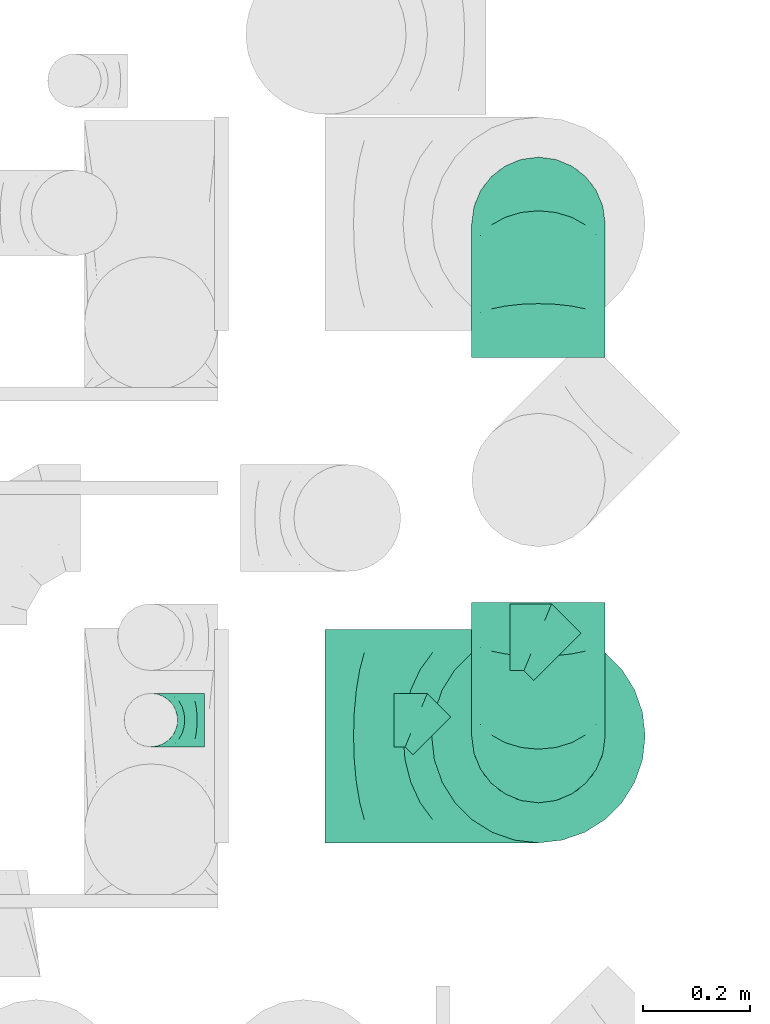
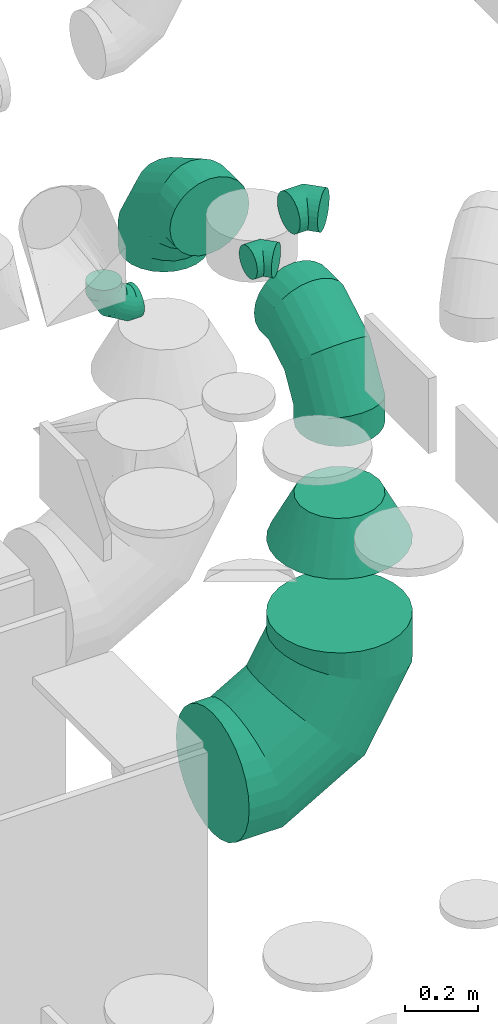
# One storey, part 26 of 59: 7 flow fittings.
"""IFC2X3 building model written with IfcOpenShell, lengths in millimetres."""

from ifc_helpers import new_model, entity, si_unit, converted_unit, derived_unit, direction, frame, origin, place, context, subcontext, project, spatial, faceted_brep, source, transform, mapped, material, type_object, type_shapes, element, save


model = new_model("IFC2X3")

# Units and contexts
model_context = context("Model", 3, precision=0.01, world=origin(), true_north=direction((6.12303176911189e-17, 1.0)))
body_context = subcontext(model_context, "Body", "Model", "MODEL_VIEW")
ifc_project = project(units=[si_unit("LENGTHUNIT", "METRE", prefix="MILLI"), si_unit("AREAUNIT", "SQUARE_METRE"), si_unit("VOLUMEUNIT", "CUBIC_METRE"), converted_unit("PLANEANGLEUNIT", "DEGREE", entity("IfcRatioMeasure", 0.0174532925199433), si_unit("PLANEANGLEUNIT", "RADIAN"), dimensions=[0, 0, 0, 0, 0, 0, 0]), si_unit("MASSUNIT", "GRAM", prefix="KILO"), derived_unit("MASSDENSITYUNIT", [(si_unit("MASSUNIT", "GRAM", prefix="KILO"), 1), (si_unit("LENGTHUNIT", "METRE"), -3)]), derived_unit("MOMENTOFINERTIAUNIT", [(si_unit("LENGTHUNIT", "METRE"), 4)]), si_unit("TIMEUNIT", "SECOND"), si_unit("FREQUENCYUNIT", "HERTZ"), si_unit("THERMODYNAMICTEMPERATUREUNIT", "DEGREE_CELSIUS"), derived_unit("THERMALTRANSMITTANCEUNIT", [(si_unit("MASSUNIT", "GRAM", prefix="KILO"), 1), (si_unit("THERMODYNAMICTEMPERATUREUNIT", "KELVIN"), -1), (si_unit("TIMEUNIT", "SECOND"), -3)]), derived_unit("VOLUMETRICFLOWRATEUNIT", [(si_unit("LENGTHUNIT", "METRE"), 3), (si_unit("TIMEUNIT", "SECOND"), -1)]), derived_unit("MASSFLOWRATEUNIT", [(si_unit("MASSUNIT", "GRAM", prefix="KILO"), 1), (si_unit("TIMEUNIT", "SECOND"), -1)]), derived_unit("ROTATIONALFREQUENCYUNIT", [(si_unit("TIMEUNIT", "SECOND"), -1)]), si_unit("ELECTRICCURRENTUNIT", "AMPERE"), si_unit("ELECTRICVOLTAGEUNIT", "VOLT"), si_unit("POWERUNIT", "WATT"), si_unit("FORCEUNIT", "NEWTON", prefix="KILO"), si_unit("ILLUMINANCEUNIT", "LUX"), si_unit("LUMINOUSFLUXUNIT", "LUMEN"), si_unit("LUMINOUSINTENSITYUNIT", "CANDELA"), derived_unit("USERDEFINED", [(si_unit("MASSUNIT", "GRAM", prefix="KILO"), -1), (si_unit("LENGTHUNIT", "METRE"), -2), (si_unit("TIMEUNIT", "SECOND"), 3), (si_unit("LUMINOUSFLUXUNIT", "LUMEN"), 1)]), derived_unit("LINEARVELOCITYUNIT", [(si_unit("LENGTHUNIT", "METRE"), 1), (si_unit("TIMEUNIT", "SECOND"), -1)]), si_unit("PRESSUREUNIT", "PASCAL"), derived_unit("USERDEFINED", [(si_unit("LENGTHUNIT", "METRE"), -2), (si_unit("MASSUNIT", "GRAM", prefix="KILO"), 1), (si_unit("TIMEUNIT", "SECOND"), -2)]), derived_unit("LINEARFORCEUNIT", [(si_unit("MASSUNIT", "GRAM", prefix="KILO"), 1), (si_unit("LENGTHUNIT", "METRE"), 1), (si_unit("TIMEUNIT", "SECOND"), -2), (si_unit("LENGTHUNIT", "METRE"), -1)]), derived_unit("PLANARFORCEUNIT", [(si_unit("MASSUNIT", "GRAM", prefix="KILO"), 1), (si_unit("LENGTHUNIT", "METRE"), 1), (si_unit("TIMEUNIT", "SECOND"), -2), (si_unit("LENGTHUNIT", "METRE"), -2)])], contexts=[model_context])

# Site, building, storey
site_placement = place(None, origin())
site = spatial("IfcSite", under=ifc_project, at=site_placement, CompositionType="ELEMENT")
building_placement = place(site_placement, origin())
building = spatial("IfcBuilding", under=site, at=building_placement, CompositionType="ELEMENT")
storey_placement = place(building_placement, frame((0.0, 0.0, 28200.0)))
storey = spatial("IfcBuildingStorey", under=building, at=storey_placement, CompositionType="ELEMENT", Elevation=28200.0)

# Flow fittings
ifc_material = material()
duct_fitting_type_1 = type_object("IfcDuctFittingType", PredefinedType="NOTDEFINED", material=ifc_material)
shared_shape_1 = source(origin(), body_context, "Body", "Brep", [
    faceted_brep([(-100.0, 0.0, -50.0), (-100.0, -12.94, -48.3), (-100.0, -25.0, -43.3), (-100.0, -35.36, -35.36), (-100.0, -43.3, -25.0), (-100.0, -48.3, -12.94), (-100.0, -50.0, 0.0), (-100.0, -48.3, 12.94), (-100.0, -43.3, 25.0), (-100.0, -35.36, 35.36), (-100.0, -25.0, 43.3), (-100.0, -12.94, 48.3), (-100.0, 0.0, 50.0), (-100.0, 12.94, 48.3), (-100.0, 25.0, 43.3), (-100.0, 35.36, 35.36), (-100.0, 43.3, 25.0), (-100.0, 48.3, 12.94), (-100.0, 50.0, 0.0), (-100.0, 48.3, -12.94), (-100.0, 43.3, -25.0), (-100.0, 35.36, -35.36), (-100.0, 25.0, -43.3), (-100.0, 12.94, -48.3), (-76.67, 12.94, 48.3), (-79.9, 25.0, 43.3), (-73.21, 0.0, 50.0), (-82.68, 35.36, 35.36), (-86.15, 48.3, 12.94), (-86.6, 50.0, 0.0), (-84.81, 43.3, 25.0), (-84.81, 43.3, -25.0), (-82.68, 35.36, -35.36), (-86.15, 48.3, -12.94), (-76.67, 12.94, -48.3), (-73.21, 0.0, -50.0), (-79.9, 25.0, -43.3), (-69.74, -12.94, -48.3), (-66.51, -25.0, -43.3), (-63.73, -35.36, -35.36), (-61.6, -43.3, -25.0), (-60.26, -48.3, -12.94), (-59.81, -50.0, 0.0), (-60.26, -48.3, 12.94), (-61.6, -43.3, 25.0), (-63.73, -35.36, 35.36), (-66.51, -25.0, 43.3), (-69.74, -12.94, 48.3), (-36.27, 36.27, 48.3), (-45.1, 45.1, 43.3), (-26.79, 26.79, 50.0), (-52.68, 52.68, 35.36), (-58.49, 58.49, 25.0), (-62.15, 62.15, 12.94), (-63.4, 63.4, 0.0), (-62.15, 62.15, -12.94), (-58.49, 58.49, -25.0), (-52.68, 52.68, -35.36), (-36.27, 36.27, -48.3), (-26.79, 26.79, -50.0), (-45.1, 45.1, -43.3), (-17.32, 17.32, -48.3), (-8.49, 8.49, -43.3), (-0.91, 0.91, -35.36), (4.9, -4.9, -25.0), (8.56, -8.56, -12.94), (9.81, -9.81, 0.0), (8.56, -8.56, 12.94), (4.9, -4.9, 25.0), (-0.91, 0.91, 35.36), (-8.49, 8.49, 43.3), (-17.32, 17.32, 48.3), (-12.94, 76.67, 48.3), (-25.0, 79.9, 43.3), (0.0, 73.21, 50.0), (-35.36, 82.68, 35.36), (-43.3, 84.81, 25.0), (-48.3, 86.15, 12.94), (-50.0, 86.6, 0.0), (-48.3, 86.15, -12.94), (-43.3, 84.81, -25.0), (-35.36, 82.68, -35.36), (-12.94, 76.67, -48.3), (0.0, 73.21, -50.0), (-25.0, 79.9, -43.3), (12.94, 69.74, -48.3), (25.0, 66.51, -43.3), (35.36, 63.73, -35.36), (43.3, 61.6, -25.0), (48.3, 60.26, -12.94), (50.0, 59.81, 0.0), (48.3, 60.26, 12.94), (43.3, 61.6, 25.0), (35.36, 63.73, 35.36), (25.0, 66.51, 43.3), (12.94, 69.74, 48.3), (-12.94, 100.0, -48.3), (-25.0, 100.0, -43.3), (-35.36, 100.0, -35.36), (-43.3, 100.0, -25.0), (-48.3, 100.0, -12.94), (-50.0, 100.0, 0.0), (-48.3, 100.0, 12.94), (-43.3, 100.0, 25.0), (-35.36, 100.0, 35.36), (-25.0, 100.0, 43.3), (-12.94, 100.0, 48.3), (0.0, 100.0, 50.0), (12.94, 100.0, 48.3), (25.0, 100.0, 43.3), (35.36, 100.0, 35.36), (43.3, 100.0, 25.0), (48.3, 100.0, 12.94), (50.0, 100.0, 0.0), (48.3, 100.0, -12.94), (43.3, 100.0, -25.0), (35.36, 100.0, -35.36), (25.0, 100.0, -43.3), (12.94, 100.0, -48.3), (0.0, 100.0, -50.0)], [[[0, 1, 2, 3, 4, 5, 6, 7, 8, 9, 10, 11, 12, 13, 14, 15, 16, 17, 18, 19, 20, 21, 22, 23]], [[24, 25, 14, 13]], [[26, 24, 13, 12]], [[14, 25, 27, 15]], [[28, 29, 18, 17]], [[30, 28, 17, 16]], [[15, 27, 30, 16]], [[20, 31, 32, 21]], [[33, 31, 20, 19]], [[18, 29, 33, 19]], [[34, 35, 0, 23]], [[36, 34, 23, 22]], [[32, 36, 22, 21]], [[2, 1, 37, 38]], [[3, 2, 38, 39]], [[0, 35, 37, 1]], [[5, 4, 40, 41]], [[6, 5, 41, 42]], [[3, 39, 40, 4]], [[6, 42, 43, 7]], [[7, 43, 44, 8]], [[8, 44, 45, 9]], [[10, 46, 47, 11]], [[11, 47, 26, 12]], [[10, 9, 45, 46]], [[48, 49, 25, 24]], [[50, 48, 24, 26]], [[27, 25, 49, 51]], [[52, 53, 28, 30]], [[51, 52, 30, 27]], [[29, 28, 53, 54]], [[55, 56, 31, 33]], [[54, 55, 33, 29]], [[57, 32, 31, 56]], [[58, 59, 35, 34]], [[60, 58, 34, 36]], [[57, 60, 36, 32]], [[37, 35, 59, 61]], [[38, 37, 61, 62]], [[39, 38, 62, 63]], [[41, 40, 64, 65]], [[42, 41, 65, 66]], [[63, 64, 40, 39]], [[43, 42, 66, 67]], [[44, 43, 67, 68]], [[68, 69, 45, 44]], [[46, 45, 69, 70]], [[47, 46, 70, 71]], [[26, 47, 71, 50]], [[72, 73, 49, 48]], [[74, 72, 48, 50]], [[51, 49, 73, 75]], [[76, 77, 53, 52]], [[75, 76, 52, 51]], [[54, 53, 77, 78]], [[79, 80, 56, 55]], [[78, 79, 55, 54]], [[81, 57, 56, 80]], [[82, 83, 59, 58]], [[84, 82, 58, 60]], [[81, 84, 60, 57]], [[61, 59, 83, 85]], [[62, 61, 85, 86]], [[63, 62, 86, 87]], [[65, 64, 88, 89]], [[66, 65, 89, 90]], [[87, 88, 64, 63]], [[67, 66, 90, 91]], [[68, 67, 91, 92]], [[92, 93, 69, 68]], [[70, 69, 93, 94]], [[71, 70, 94, 95]], [[50, 71, 95, 74]], [[96, 97, 98, 99, 100, 101, 102, 103, 104, 105, 106, 107, 108, 109, 110, 111, 112, 113, 114, 115, 116, 117, 118, 119]], [[72, 74, 107, 106]], [[73, 72, 106, 105]], [[75, 73, 105, 104]], [[77, 76, 103, 102]], [[78, 77, 102, 101]], [[75, 104, 103, 76]], [[78, 101, 100, 79]], [[79, 100, 99, 80]], [[80, 99, 98, 81]], [[96, 119, 83, 82]], [[97, 96, 82, 84]], [[84, 81, 98, 97]], [[83, 119, 118, 85]], [[85, 118, 117, 86]], [[86, 117, 116, 87]], [[88, 115, 114, 89]], [[89, 114, 113, 90]], [[87, 116, 115, 88]], [[91, 90, 113, 112]], [[92, 91, 112, 111]], [[93, 92, 111, 110]], [[95, 94, 109, 108]], [[74, 95, 108, 107]], [[110, 109, 94, 93]]]),
])
type_shapes(duct_fitting_type_1, [shared_shape_1])
flow_fitting_1_placement = place(storey_placement, frame((55594.42, 10907.71, 2305.0), z_axis=(0.0, -1.0, 0.0), x_axis=(0.0, 0.0, -1.0)))
element("IfcFlowFitting", 1, at=flow_fitting_1_placement, inside=storey, type_object=duct_fitting_type_1, material=ifc_material, context=body_context, shape_type="MappedRepresentation", body=[
    mapped(shared_shape_1, transform((0.0, 0.0, 0.0), scale=1.0)),
])
duct_fitting_type_2 = type_object("IfcDuctFittingType", PredefinedType="NOTDEFINED", material=ifc_material)
shared_shape_2 = source(origin(), body_context, "Body", "Brep", [
    faceted_brep([(-250.0, 0.0, -125.0), (-250.0, -32.35, -120.74), (-250.0, -62.5, -108.25), (-250.0, -88.39, -88.39), (-250.0, -108.25, -62.5), (-250.0, -120.74, -32.35), (-250.0, -125.0, 0.0), (-250.0, -120.74, 32.35), (-250.0, -108.25, 62.5), (-250.0, -88.39, 88.39), (-250.0, -62.5, 108.25), (-250.0, -32.35, 120.74), (-250.0, 0.0, 125.0), (-250.0, 32.35, 120.74), (-250.0, 62.5, 108.25), (-250.0, 88.39, 88.39), (-250.0, 108.25, 62.5), (-250.0, 120.74, 32.35), (-250.0, 125.0, 0.0), (-250.0, 120.74, -32.35), (-250.0, 108.25, -62.5), (-250.0, 88.39, -88.39), (-250.0, 62.5, -108.25), (-250.0, 32.35, -120.74), (-191.68, 32.35, 120.74), (-199.76, 62.5, 108.25), (-183.01, 0.0, 125.0), (-206.7, 88.39, 88.39), (-215.37, 120.74, 32.35), (-216.51, 125.0, 0.0), (-212.02, 108.25, 62.5), (-212.02, 108.25, -62.5), (-206.7, 88.39, -88.39), (-215.37, 120.74, -32.35), (-191.68, 32.35, -120.74), (-183.01, 0.0, -125.0), (-199.76, 62.5, -108.25), (-174.34, -32.35, -120.74), (-166.27, -62.5, -108.25), (-159.33, -88.39, -88.39), (-154.01, -108.25, -62.5), (-150.66, -120.74, -32.35), (-149.52, -125.0, 0.0), (-150.66, -120.74, 32.35), (-154.01, -108.25, 62.5), (-159.33, -88.39, 88.39), (-166.27, -62.5, 108.25), (-174.34, -32.35, 120.74), (-90.67, 90.67, 120.74), (-112.74, 112.74, 108.25), (-66.99, 66.99, 125.0), (-131.69, 131.69, 88.39), (-146.23, 146.23, 62.5), (-155.38, 155.38, 32.35), (-158.49, 158.49, 0.0), (-155.38, 155.38, -32.35), (-146.23, 146.23, -62.5), (-131.69, 131.69, -88.39), (-90.67, 90.67, -120.74), (-66.99, 66.99, -125.0), (-112.74, 112.74, -108.25), (-43.3, 43.3, -120.74), (-21.23, 21.23, -108.25), (-2.28, 2.28, -88.39), (12.26, -12.26, -62.5), (21.4, -21.4, -32.35), (24.52, -24.52, 0.0), (21.4, -21.4, 32.35), (12.26, -12.26, 62.5), (-2.28, 2.28, 88.39), (-21.23, 21.23, 108.25), (-43.3, 43.3, 120.74), (-32.35, 191.68, 120.74), (-62.5, 199.76, 108.25), (0.0, 183.01, 125.0), (-88.39, 206.7, 88.39), (-108.25, 212.02, 62.5), (-120.74, 215.37, 32.35), (-125.0, 216.51, 0.0), (-120.74, 215.37, -32.35), (-108.25, 212.02, -62.5), (-88.39, 206.7, -88.39), (-32.35, 191.68, -120.74), (0.0, 183.01, -125.0), (-62.5, 199.76, -108.25), (32.35, 174.34, -120.74), (62.5, 166.27, -108.25), (88.39, 159.33, -88.39), (108.25, 154.01, -62.5), (120.74, 150.66, -32.35), (125.0, 149.52, 0.0), (120.74, 150.66, 32.35), (108.25, 154.01, 62.5), (88.39, 159.33, 88.39), (62.5, 166.27, 108.25), (32.35, 174.34, 120.74), (-32.35, 250.0, -120.74), (-62.5, 250.0, -108.25), (-88.39, 250.0, -88.39), (-108.25, 250.0, -62.5), (-120.74, 250.0, -32.35), (-125.0, 250.0, 0.0), (-120.74, 250.0, 32.35), (-108.25, 250.0, 62.5), (-88.39, 250.0, 88.39), (-62.5, 250.0, 108.25), (-32.35, 250.0, 120.74), (0.0, 250.0, 125.0), (32.35, 250.0, 120.74), (62.5, 250.0, 108.25), (88.39, 250.0, 88.39), (108.25, 250.0, 62.5), (120.74, 250.0, 32.35), (125.0, 250.0, 0.0), (120.74, 250.0, -32.35), (108.25, 250.0, -62.5), (88.39, 250.0, -88.39), (62.5, 250.0, -108.25), (32.35, 250.0, -120.74), (0.0, 250.0, -125.0)], [[[0, 1, 2, 3, 4, 5, 6, 7, 8, 9, 10, 11, 12, 13, 14, 15, 16, 17, 18, 19, 20, 21, 22, 23]], [[24, 25, 14, 13]], [[26, 24, 13, 12]], [[14, 25, 27, 15]], [[28, 29, 18, 17]], [[30, 28, 17, 16]], [[15, 27, 30, 16]], [[20, 31, 32, 21]], [[33, 31, 20, 19]], [[18, 29, 33, 19]], [[34, 35, 0, 23]], [[36, 34, 23, 22]], [[21, 32, 36, 22]], [[1, 0, 35, 37]], [[2, 1, 37, 38]], [[38, 39, 3, 2]], [[5, 4, 40, 41]], [[6, 5, 41, 42]], [[39, 40, 4, 3]], [[6, 42, 43, 7]], [[7, 43, 44, 8]], [[8, 44, 45, 9]], [[9, 45, 46, 10]], [[10, 46, 47, 11]], [[26, 12, 11, 47]], [[48, 49, 25, 24]], [[50, 48, 24, 26]], [[27, 25, 49, 51]], [[52, 53, 28, 30]], [[51, 52, 30, 27]], [[29, 28, 53, 54]], [[55, 56, 31, 33]], [[54, 55, 33, 29]], [[32, 31, 56, 57]], [[58, 59, 35, 34]], [[60, 58, 34, 36]], [[57, 60, 36, 32]], [[37, 35, 59, 61]], [[38, 37, 61, 62]], [[39, 38, 62, 63]], [[41, 40, 64, 65]], [[42, 41, 65, 66]], [[63, 64, 40, 39]], [[43, 42, 66, 67]], [[44, 43, 67, 68]], [[68, 69, 45, 44]], [[46, 45, 69, 70]], [[47, 46, 70, 71]], [[26, 47, 71, 50]], [[72, 73, 49, 48]], [[74, 72, 48, 50]], [[51, 49, 73, 75]], [[76, 77, 53, 52]], [[75, 76, 52, 51]], [[54, 53, 77, 78]], [[79, 80, 56, 55]], [[78, 79, 55, 54]], [[57, 56, 80, 81]], [[82, 83, 59, 58]], [[84, 82, 58, 60]], [[81, 84, 60, 57]], [[61, 59, 83, 85]], [[62, 61, 85, 86]], [[63, 62, 86, 87]], [[65, 64, 88, 89]], [[66, 65, 89, 90]], [[87, 88, 64, 63]], [[67, 66, 90, 91]], [[68, 67, 91, 92]], [[92, 93, 69, 68]], [[70, 69, 93, 94]], [[71, 70, 94, 95]], [[50, 71, 95, 74]], [[96, 97, 98, 99, 100, 101, 102, 103, 104, 105, 106, 107, 108, 109, 110, 111, 112, 113, 114, 115, 116, 117, 118, 119]], [[72, 74, 107, 106]], [[73, 72, 106, 105]], [[75, 73, 105, 104]], [[77, 76, 103, 102]], [[78, 77, 102, 101]], [[75, 104, 103, 76]], [[78, 101, 100, 79]], [[79, 100, 99, 80]], [[80, 99, 98, 81]], [[84, 97, 96, 82]], [[82, 96, 119, 83]], [[84, 81, 98, 97]], [[83, 119, 118, 85]], [[85, 118, 117, 86]], [[116, 87, 86, 117]], [[88, 115, 114, 89]], [[89, 114, 113, 90]], [[115, 88, 87, 116]], [[91, 90, 113, 112]], [[92, 91, 112, 111]], [[111, 110, 93, 92]], [[95, 94, 109, 108]], [[74, 95, 108, 107]], [[110, 109, 94, 93]]]),
])
type_shapes(duct_fitting_type_2, [shared_shape_2])
for number, where, z_axis, x_axis in (
    (2, (56320.5, 10877.69, 1950.82), (1.0, 0.0, 0.0), (0.0, -1.0, 0.0)),
    (3, (56320.5, 11837.37, 1950.82), (-1.0, 0.0, 0.0), (0.0, 1.0, 0.0)),
):
    element("IfcFlowFitting", number, at=place(storey_placement, frame(where, z_axis=z_axis, x_axis=x_axis)), inside=storey, type_object=duct_fitting_type_2, material=ifc_material, context=body_context, shape_type="MappedRepresentation", body=[
        mapped(shared_shape_2, transform((0.0, 0.0, 0.0), scale=1.0)),
    ])
duct_fitting_type_3 = type_object("IfcDuctFittingType", PredefinedType="NOTDEFINED", material=ifc_material)
shared_shape_3 = source(origin(), body_context, "Body", "Brep", [
    faceted_brep([(-51.78, 0.0, -62.5), (-51.78, -16.18, -60.37), (-51.78, -31.25, -54.13), (-51.78, -44.19, -44.19), (-51.78, -54.13, -31.25), (-51.78, -60.37, -16.18), (-51.78, -62.5, 0.0), (-51.78, -60.37, 16.18), (-51.78, -54.13, 31.25), (-51.78, -44.19, 44.19), (-51.78, -31.25, 54.13), (-51.78, -16.18, 60.37), (-51.78, 0.0, 62.5), (-51.78, 16.18, 60.37), (-51.78, 31.25, 54.13), (-51.78, 44.19, 44.19), (-51.78, 54.13, 31.25), (-51.78, 60.37, 16.18), (-51.78, 62.5, 0.0), (-51.78, 60.37, -16.18), (-51.78, 54.13, -31.25), (-51.78, 44.19, -44.19), (-51.78, 31.25, -54.13), (-51.78, 16.18, -60.37), (-6.7, 16.18, 60.37), (-12.94, 31.25, 54.13), (0.0, 0.0, 62.5), (-18.31, 44.19, 44.19), (-22.42, 54.13, 31.25), (-25.01, 60.37, 16.18), (-25.89, 62.5, 0.0), (-25.01, 60.37, -16.18), (-22.42, 54.13, -31.25), (-18.31, 44.19, -44.19), (-6.7, 16.18, -60.37), (0.0, 0.0, -62.5), (-12.94, 31.25, -54.13), (6.7, -16.18, -60.37), (12.94, -31.25, -54.13), (18.31, -44.19, -44.19), (22.42, -54.13, -31.25), (25.01, -60.37, -16.18), (25.89, -62.5, 0.0), (25.01, -60.37, 16.18), (22.42, -54.13, 31.25), (18.31, -44.19, 44.19), (12.94, -31.25, 54.13), (6.7, -16.18, 60.37), (25.17, 48.05, 60.37), (14.51, 58.71, 54.13), (36.61, 36.61, 62.5), (5.36, 67.86, 44.19), (-1.66, 74.88, 31.25), (-6.08, 79.3, 16.18), (-7.58, 80.81, 0.0), (-6.08, 79.3, -16.18), (-1.66, 74.88, -31.25), (5.36, 67.86, -44.19), (14.51, 58.71, -54.13), (25.17, 48.05, -60.37), (36.61, 36.61, -62.5), (48.05, 25.17, -60.37), (58.71, 14.51, -54.13), (67.86, 5.36, -44.19), (74.88, -1.66, -31.25), (79.3, -6.08, -16.18), (80.81, -7.58, 0.0), (79.3, -6.08, 16.18), (74.88, -1.66, 31.25), (67.86, 5.36, 44.19), (58.71, 14.51, 54.13), (48.05, 25.17, 60.37)], [[[0, 1, 2, 3, 4, 5, 6, 7, 8, 9, 10, 11, 12, 13, 14, 15, 16, 17, 18, 19, 20, 21, 22, 23]], [[24, 25, 14, 13]], [[26, 24, 13, 12]], [[27, 15, 14, 25]], [[28, 29, 17, 16]], [[28, 16, 15, 27]], [[30, 18, 17, 29]], [[31, 32, 20, 19]], [[30, 31, 19, 18]], [[21, 20, 32, 33]], [[34, 35, 0, 23]], [[36, 34, 23, 22]], [[33, 36, 22, 21]], [[1, 0, 35, 37]], [[2, 1, 37, 38]], [[38, 39, 3, 2]], [[5, 4, 40, 41]], [[6, 5, 41, 42]], [[39, 40, 4, 3]], [[6, 42, 43, 7]], [[7, 43, 44, 8]], [[8, 44, 45, 9]], [[9, 45, 46, 10]], [[10, 46, 47, 11]], [[26, 12, 11, 47]], [[48, 49, 25, 24]], [[50, 48, 24, 26]], [[27, 25, 49, 51]], [[29, 28, 52, 53]], [[30, 29, 53, 54]], [[51, 52, 28, 27]], [[30, 54, 55, 31]], [[31, 55, 56, 32]], [[57, 33, 32, 56]], [[36, 58, 59, 34]], [[34, 59, 60, 35]], [[58, 36, 33, 57]], [[35, 60, 61, 37]], [[37, 61, 62, 38]], [[63, 39, 38, 62]], [[40, 64, 65, 41]], [[41, 65, 66, 42]], [[64, 40, 39, 63]], [[43, 42, 66, 67]], [[44, 43, 67, 68]], [[68, 69, 45, 44]], [[47, 46, 70, 71]], [[26, 47, 71, 50]], [[69, 70, 46, 45]], [[59, 58, 57, 56, 55, 54, 53, 52, 51, 49, 48, 50, 71, 70, 69, 68, 67, 66, 65, 64, 63, 62, 61, 60]]]),
])
type_shapes(duct_fitting_type_3, [shared_shape_3])
flow_fitting_2_placement = place(storey_placement, frame((56319.31, 11063.0, 2300.0), z_axis=(0.0, 0.0, 1.0), x_axis=(-0.707106781186547, 0.707106781186548, 0.0)))
element("IfcFlowFitting", 4, at=flow_fitting_2_placement, inside=storey, type_object=duct_fitting_type_3, material=ifc_material, context=body_context, shape_type="MappedRepresentation", body=[
    mapped(shared_shape_3, transform((0.0, 0.0, 0.0), scale=1.0)),
])
duct_fitting_type_4 = type_object("IfcDuctFittingType", PredefinedType="NOTDEFINED", material=ifc_material)
shared_shape_4 = source(origin(), body_context, "Body", "Brep", [
    faceted_brep([(-400.0, 0.0, -200.0), (-400.0, -44.5, -194.99), (-400.0, -86.78, -180.19), (-400.0, -124.7, -156.37), (-400.0, -156.37, -124.7), (-400.0, -180.19, -86.78), (-400.0, -194.99, -44.5), (-400.0, -200.0, 0.0), (-400.0, -194.99, 44.5), (-400.0, -180.19, 86.78), (-400.0, -156.37, 124.7), (-400.0, -124.7, 156.37), (-400.0, -86.78, 180.19), (-400.0, -44.5, 194.99), (-400.0, 0.0, 200.0), (-400.0, 44.5, 194.99), (-400.0, 86.78, 180.19), (-400.0, 124.7, 156.37), (-400.0, 156.37, 124.7), (-400.0, 180.19, 86.78), (-400.0, 194.99, 44.5), (-400.0, 200.0, 0.0), (-400.0, 194.99, -44.5), (-400.0, 180.19, -86.78), (-400.0, 156.37, -124.7), (-400.0, 124.7, -156.37), (-400.0, 86.78, -180.19), (-400.0, 44.5, -194.99), (-292.82, 0.0, 200.0), (-304.75, 44.5, 194.99), (-316.07, 86.78, 180.19), (-326.23, 124.7, 156.37), (-334.72, 156.37, 124.7), (-341.1, 180.19, 86.78), (-345.07, 194.99, 44.5), (-346.41, 200.0, 0.0), (-345.07, 194.99, -44.5), (-341.1, 180.19, -86.78), (-334.72, 156.37, -124.7), (-326.23, 124.7, -156.37), (-316.07, 86.78, -180.19), (-304.75, 44.5, -194.99), (-292.82, 0.0, -200.0), (-280.9, -44.5, -194.99), (-269.57, -86.78, -180.19), (-259.41, -124.7, -156.37), (-250.92, -156.37, -124.7), (-244.54, -180.19, -86.78), (-240.57, -194.99, -44.5), (-239.23, -200.0, 0.0), (-240.57, -194.99, 44.5), (-244.54, -180.19, 86.78), (-250.92, -156.37, 124.7), (-259.41, -124.7, 156.37), (-269.57, -86.78, 180.19), (-280.9, -44.5, 194.99), (-107.18, 107.18, 200.0), (-139.76, 139.76, 194.99), (-170.7, 170.7, 180.19), (-198.46, 198.46, 156.37), (-221.65, 221.65, 124.7), (-239.09, 239.09, 86.78), (-249.92, 249.92, 44.5), (-253.59, 253.59, 0.0), (-249.92, 249.92, -44.5), (-239.09, 239.09, -86.78), (-221.65, 221.65, -124.7), (-198.46, 198.46, -156.37), (-170.7, 170.7, -180.19), (-139.76, 139.76, -194.99), (-107.18, 107.18, -200.0), (-74.6, 74.6, -194.99), (-43.65, 43.65, -180.19), (-15.89, 15.89, -156.37), (7.29, -7.29, -124.7), (24.73, -24.73, -86.78), (35.56, -35.56, -44.5), (39.23, -39.23, 0.0), (35.56, -35.56, 44.5), (24.73, -24.73, 86.78), (7.29, -7.29, 124.7), (-15.89, 15.89, 156.37), (-43.65, 43.65, 180.19), (-74.6, 74.6, 194.99), (0.0, 292.82, 200.0), (-44.5, 304.75, 194.99), (-86.78, 316.07, 180.19), (-124.7, 326.23, 156.37), (-156.37, 334.72, 124.7), (-180.19, 341.1, 86.78), (-194.99, 345.07, 44.5), (-200.0, 346.41, 0.0), (-194.99, 345.07, -44.5), (-180.19, 341.1, -86.78), (-156.37, 334.72, -124.7), (-124.7, 326.23, -156.37), (-86.78, 316.07, -180.19), (-44.5, 304.75, -194.99), (0.0, 292.82, -200.0), (44.5, 280.9, -194.99), (86.78, 269.57, -180.19), (124.7, 259.41, -156.37), (156.37, 250.92, -124.7), (180.19, 244.54, -86.78), (194.99, 240.57, -44.5), (200.0, 239.23, 0.0), (194.99, 240.57, 44.5), (180.19, 244.54, 86.78), (156.37, 250.92, 124.7), (124.7, 259.41, 156.37), (86.78, 269.57, 180.19), (44.5, 280.9, 194.99), (-44.5, 400.0, -194.99), (-86.78, 400.0, -180.19), (-124.7, 400.0, -156.37), (-156.37, 400.0, -124.7), (-180.19, 400.0, -86.78), (-194.99, 400.0, -44.5), (-200.0, 400.0, 0.0), (-194.99, 400.0, 44.5), (-180.19, 400.0, 86.78), (-156.37, 400.0, 124.7), (-124.7, 400.0, 156.37), (-86.78, 400.0, 180.19), (-44.5, 400.0, 194.99), (0.0, 400.0, 200.0), (44.5, 400.0, 194.99), (86.78, 400.0, 180.19), (124.7, 400.0, 156.37), (156.37, 400.0, 124.7), (180.19, 400.0, 86.78), (194.99, 400.0, 44.5), (200.0, 400.0, 0.0), (194.99, 400.0, -44.5), (180.19, 400.0, -86.78), (156.37, 400.0, -124.7), (124.7, 400.0, -156.37), (86.78, 400.0, -180.19), (44.5, 400.0, -194.99), (0.0, 400.0, -200.0)], [[[0, 1, 2, 3, 4, 5, 6, 7, 8, 9, 10, 11, 12, 13, 14, 15, 16, 17, 18, 19, 20, 21, 22, 23, 24, 25, 26, 27]], [[28, 29, 15, 14]], [[30, 31, 17, 16]], [[29, 30, 16, 15]], [[31, 32, 18, 17]], [[32, 33, 19, 18]], [[34, 35, 21, 20]], [[33, 34, 20, 19]], [[35, 36, 22, 21]], [[37, 38, 24, 23]], [[36, 37, 23, 22]], [[38, 39, 25, 24]], [[39, 40, 26, 25]], [[41, 42, 0, 27]], [[40, 41, 27, 26]], [[1, 0, 42, 43]], [[43, 44, 2, 1]], [[45, 3, 2, 44]], [[45, 46, 4, 3]], [[5, 4, 46, 47]], [[47, 48, 6, 5]], [[49, 7, 6, 48]], [[7, 49, 50, 8]], [[8, 50, 51, 9]], [[9, 51, 52, 10]], [[52, 53, 11, 10]], [[11, 53, 54, 12]], [[12, 54, 55, 13]], [[13, 55, 28, 14]], [[56, 57, 29, 28]], [[58, 59, 31, 30]], [[57, 58, 30, 29]], [[59, 60, 32, 31]], [[60, 61, 33, 32]], [[62, 63, 35, 34]], [[61, 62, 34, 33]], [[63, 64, 36, 35]], [[65, 66, 38, 37]], [[64, 65, 37, 36]], [[66, 67, 39, 38]], [[67, 68, 40, 39]], [[69, 70, 42, 41]], [[68, 69, 41, 40]], [[43, 42, 70, 71]], [[71, 72, 44, 43]], [[73, 45, 44, 72]], [[73, 74, 46, 45]], [[47, 46, 74, 75]], [[75, 76, 48, 47]], [[77, 49, 48, 76]], [[50, 49, 77, 78]], [[51, 50, 78, 79]], [[52, 51, 79, 80]], [[80, 81, 53, 52]], [[54, 53, 81, 82]], [[55, 54, 82, 83]], [[28, 55, 83, 56]], [[84, 85, 57, 56]], [[86, 87, 59, 58]], [[85, 86, 58, 57]], [[87, 88, 60, 59]], [[88, 89, 61, 60]], [[90, 91, 63, 62]], [[89, 90, 62, 61]], [[91, 92, 64, 63]], [[93, 94, 66, 65]], [[92, 93, 65, 64]], [[94, 95, 67, 66]], [[95, 96, 68, 67]], [[97, 98, 70, 69]], [[96, 97, 69, 68]], [[71, 70, 98, 99]], [[99, 100, 72, 71]], [[101, 73, 72, 100]], [[101, 102, 74, 73]], [[75, 74, 102, 103]], [[103, 104, 76, 75]], [[105, 77, 76, 104]], [[78, 77, 105, 106]], [[79, 78, 106, 107]], [[80, 79, 107, 108]], [[108, 109, 81, 80]], [[82, 81, 109, 110]], [[83, 82, 110, 111]], [[56, 83, 111, 84]], [[112, 113, 114, 115, 116, 117, 118, 119, 120, 121, 122, 123, 124, 125, 126, 127, 128, 129, 130, 131, 132, 133, 134, 135, 136, 137, 138, 139]], [[85, 84, 125, 124]], [[86, 85, 124, 123]], [[87, 86, 123, 122]], [[122, 121, 88, 87]], [[89, 88, 121, 120]], [[90, 89, 120, 119]], [[91, 90, 119, 118]], [[91, 118, 117, 92]], [[92, 117, 116, 93]], [[93, 116, 115, 94]], [[115, 114, 95, 94]], [[95, 114, 113, 96]], [[96, 113, 112, 97]], [[97, 112, 139, 98]], [[98, 139, 138, 99]], [[99, 138, 137, 100]], [[100, 137, 136, 101]], [[136, 135, 102, 101]], [[102, 135, 134, 103]], [[103, 134, 133, 104]], [[104, 133, 132, 105]], [[106, 105, 132, 131]], [[107, 106, 131, 130]], [[108, 107, 130, 129]], [[129, 128, 109, 108]], [[110, 109, 128, 127]], [[111, 110, 127, 126]], [[84, 111, 126, 125]]]),
])
type_shapes(duct_fitting_type_4, [shared_shape_4])
flow_fitting_3_placement = place(storey_placement, frame((56320.5, 10877.69, 665.0), z_axis=(0.0, 1.0, 0.0), x_axis=(0.0, 0.0, -1.0)))
element("IfcFlowFitting", 5, at=flow_fitting_3_placement, inside=storey, type_object=duct_fitting_type_4, material=ifc_material, context=body_context, shape_type="MappedRepresentation", body=[
    mapped(shared_shape_4, transform((0.0, 0.0, 0.0), scale=1.0)),
])
duct_fitting_type_5 = type_object("IfcDuctFittingType", PredefinedType="NOTDEFINED", material=ifc_material)
shared_shape_5 = source(origin(), body_context, "Body", "Brep", [
    faceted_brep([(-41.42, 0.0, -50.0), (-41.42, -12.94, -48.3), (-41.42, -25.0, -43.3), (-41.42, -35.36, -35.36), (-41.42, -43.3, -25.0), (-41.42, -48.3, -12.94), (-41.42, -50.0, 0.0), (-41.42, -48.3, 12.94), (-41.42, -43.3, 25.0), (-41.42, -35.36, 35.36), (-41.42, -25.0, 43.3), (-41.42, -12.94, 48.3), (-41.42, 0.0, 50.0), (-41.42, 12.94, 48.3), (-41.42, 25.0, 43.3), (-41.42, 35.36, 35.36), (-41.42, 43.3, 25.0), (-41.42, 48.3, 12.94), (-41.42, 50.0, 0.0), (-41.42, 48.3, -12.94), (-41.42, 43.3, -25.0), (-41.42, 35.36, -35.36), (-41.42, 25.0, -43.3), (-41.42, 12.94, -48.3), (-5.36, 12.94, 48.3), (-10.36, 25.0, 43.3), (0.0, 0.0, 50.0), (-14.64, 35.36, 35.36), (-20.0, 48.3, 12.94), (-20.71, 50.0, 0.0), (-17.94, 43.3, 25.0), (-17.94, 43.3, -25.0), (-14.64, 35.36, -35.36), (-20.0, 48.3, -12.94), (-5.36, 12.94, -48.3), (0.0, 0.0, -50.0), (-10.36, 25.0, -43.3), (5.36, -12.94, -48.3), (10.36, -25.0, -43.3), (14.64, -35.36, -35.36), (17.94, -43.3, -25.0), (20.0, -48.3, -12.94), (20.71, -50.0, 0.0), (20.0, -48.3, 12.94), (17.94, -43.3, 25.0), (14.64, -35.36, 35.36), (10.36, -25.0, 43.3), (5.36, -12.94, 48.3), (29.29, 29.29, 50.0), (20.14, 38.44, 48.3), (11.61, 46.97, 43.3), (4.29, 54.29, 35.36), (-1.33, 59.91, 25.0), (-4.86, 63.44, 12.94), (-6.07, 64.64, 0.0), (-4.86, 63.44, -12.94), (-1.33, 59.91, -25.0), (4.29, 54.29, -35.36), (11.61, 46.97, -43.3), (20.14, 38.44, -48.3), (29.29, 29.29, -50.0), (38.44, 20.14, -48.3), (46.97, 11.61, -43.3), (54.29, 4.29, -35.36), (59.91, -1.33, -25.0), (63.44, -4.86, -12.94), (64.64, -6.07, 0.0), (63.44, -4.86, 12.94), (59.91, -1.33, 25.0), (54.29, 4.29, 35.36), (46.97, 11.61, 43.3), (38.44, 20.14, 48.3)], [[[0, 1, 2, 3, 4, 5, 6, 7, 8, 9, 10, 11, 12, 13, 14, 15, 16, 17, 18, 19, 20, 21, 22, 23]], [[24, 25, 14, 13]], [[26, 24, 13, 12]], [[14, 25, 27, 15]], [[28, 29, 18, 17]], [[30, 28, 17, 16]], [[16, 15, 27, 30]], [[20, 31, 32, 21]], [[33, 31, 20, 19]], [[18, 29, 33, 19]], [[34, 35, 0, 23]], [[36, 34, 23, 22]], [[32, 36, 22, 21]], [[1, 0, 35, 37]], [[2, 1, 37, 38]], [[38, 39, 3, 2]], [[5, 4, 40, 41]], [[6, 5, 41, 42]], [[39, 40, 4, 3]], [[6, 42, 43, 7]], [[7, 43, 44, 8]], [[8, 44, 45, 9]], [[9, 45, 46, 10]], [[10, 46, 47, 11]], [[26, 12, 11, 47]], [[24, 26, 48, 49]], [[25, 24, 49, 50]], [[27, 25, 50, 51]], [[28, 30, 52, 53]], [[29, 28, 53, 54]], [[27, 51, 52, 30]], [[29, 54, 55, 33]], [[33, 55, 56, 31]], [[31, 56, 57, 32]], [[36, 58, 59, 34]], [[34, 59, 60, 35]], [[36, 32, 57, 58]], [[61, 62, 38, 37]], [[60, 61, 37, 35]], [[63, 39, 38, 62]], [[40, 64, 65, 41]], [[41, 65, 66, 42]], [[64, 40, 39, 63]], [[43, 42, 66, 67]], [[44, 43, 67, 68]], [[68, 69, 45, 44]], [[47, 46, 70, 71]], [[26, 47, 71, 48]], [[69, 70, 46, 45]], [[59, 58, 57, 56, 55, 54, 53, 52, 51, 50, 49, 48, 71, 70, 69, 68, 67, 66, 65, 64, 63, 62, 61, 60]]]),
])
type_shapes(duct_fitting_type_5, [shared_shape_5])
flow_fitting_4_placement = place(storey_placement, frame((56091.6, 10907.71, 2305.0), z_axis=(0.0, 0.0, 1.0), x_axis=(-0.707106781186546, 0.707106781186549, 0.0)))
element("IfcFlowFitting", 6, at=flow_fitting_4_placement, inside=storey, type_object=duct_fitting_type_5, material=ifc_material, context=body_context, shape_type="MappedRepresentation", body=[
    mapped(shared_shape_5, transform((0.0, 0.0, 0.0), scale=1.0)),
])
duct_fitting_type_6 = type_object("IfcDuctFittingType", PredefinedType="NOTDEFINED", material=ifc_material)
shared_shape_6 = source(origin(), body_context, "Body", "Brep", [
    faceted_brep([(150.0, -86.78, -180.19), (150.0, -44.5, -194.99), (150.0, 0.0, -200.0), (150.0, 44.5, -194.99), (150.0, 86.78, -180.19), (150.0, 124.7, -156.37), (150.0, 156.37, -124.7), (150.0, 180.19, -86.78), (150.0, 194.99, -44.5), (150.0, 200.0, 0.0), (150.0, 194.99, 44.5), (150.0, 180.19, 86.78), (150.0, 156.37, 124.7), (150.0, 124.7, 156.37), (150.0, 86.78, 180.19), (150.0, 44.5, 194.99), (150.0, 0.0, 200.0), (150.0, -44.5, 194.99), (150.0, -86.78, 180.19), (150.0, -124.7, 156.37), (150.0, -156.37, 124.7), (150.0, -180.19, 86.78), (150.0, -194.99, 44.5), (150.0, -200.0, 0.0), (150.0, -194.99, -44.5), (150.0, -180.19, -86.78), (150.0, -156.37, -124.7), (150.0, -124.7, -156.37), (0.0, 38.63, -118.88), (0.0, 0.0, -125.0), (0.0, -38.63, -118.88), (0.0, -73.47, -101.13), (0.0, -101.13, -73.47), (0.0, -118.88, -38.63), (0.0, -125.0, 0.0), (0.0, -118.88, 38.63), (0.0, -101.13, 73.47), (0.0, -73.47, 101.13), (0.0, -38.63, 118.88), (0.0, 0.0, 125.0), (0.0, 38.63, 118.88), (0.0, 73.47, 101.13), (0.0, 101.13, 73.47), (0.0, 118.88, 38.63), (0.0, 125.0, 0.0), (0.0, 118.88, -38.63), (0.0, 101.13, -73.47), (0.0, 73.47, -101.13)], [[[0, 1, 2, 3, 4, 5, 6, 7, 8, 9, 10, 11, 12, 13, 14, 15, 16, 17, 18, 19, 20, 21, 22, 23, 24, 25, 26, 27]], [[28, 29, 30, 31, 32, 33, 34, 35, 36, 37, 38, 39, 40, 41, 42, 43, 44, 45, 46, 47]], [[10, 44, 43]], [[11, 43, 42]], [[10, 9, 44]], [[12, 11, 42]], [[10, 43, 11]], [[42, 41, 13, 12]], [[40, 39, 15]], [[41, 40, 14]], [[13, 41, 14]], [[14, 40, 15]], [[39, 16, 15]], [[17, 39, 38]], [[18, 38, 37]], [[17, 16, 39]], [[19, 18, 37]], [[17, 38, 18]], [[37, 36, 20, 19]], [[35, 34, 22]], [[36, 35, 21]], [[20, 36, 21]], [[21, 35, 22]], [[34, 23, 22]], [[24, 34, 33]], [[25, 33, 32]], [[24, 23, 34]], [[26, 25, 32]], [[24, 33, 25]], [[32, 31, 27, 26]], [[30, 29, 1]], [[31, 30, 0]], [[27, 31, 0]], [[0, 30, 1]], [[29, 2, 1]], [[3, 29, 28]], [[4, 28, 47]], [[3, 2, 29]], [[5, 4, 47]], [[3, 28, 4]], [[47, 46, 6, 5]], [[45, 44, 8]], [[46, 45, 7]], [[6, 46, 7]], [[7, 45, 8]], [[44, 9, 8]]]),
])
type_shapes(duct_fitting_type_6, [shared_shape_6])
flow_fitting_5_placement = place(storey_placement, frame((56320.5, 10877.69, 1460.82), z_axis=(0.0, -1.0, 0.0), x_axis=(0.0, 0.0, -1.0)))
element("IfcFlowFitting", 7, at=flow_fitting_5_placement, inside=storey, type_object=duct_fitting_type_6, material=ifc_material, context=body_context, shape_type="MappedRepresentation", body=[
    mapped(shared_shape_6, transform((0.0, 0.0, 0.0), scale=1.0)),
])

save(model, "model.ifc")
